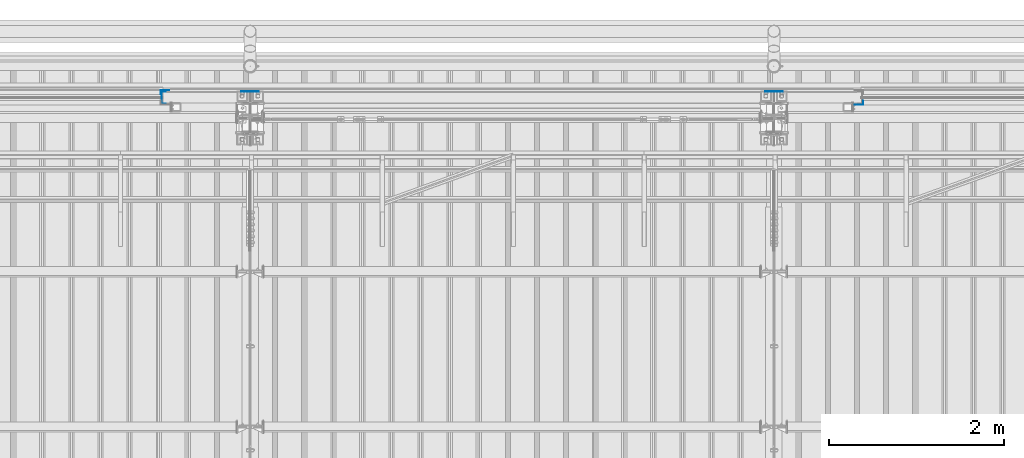
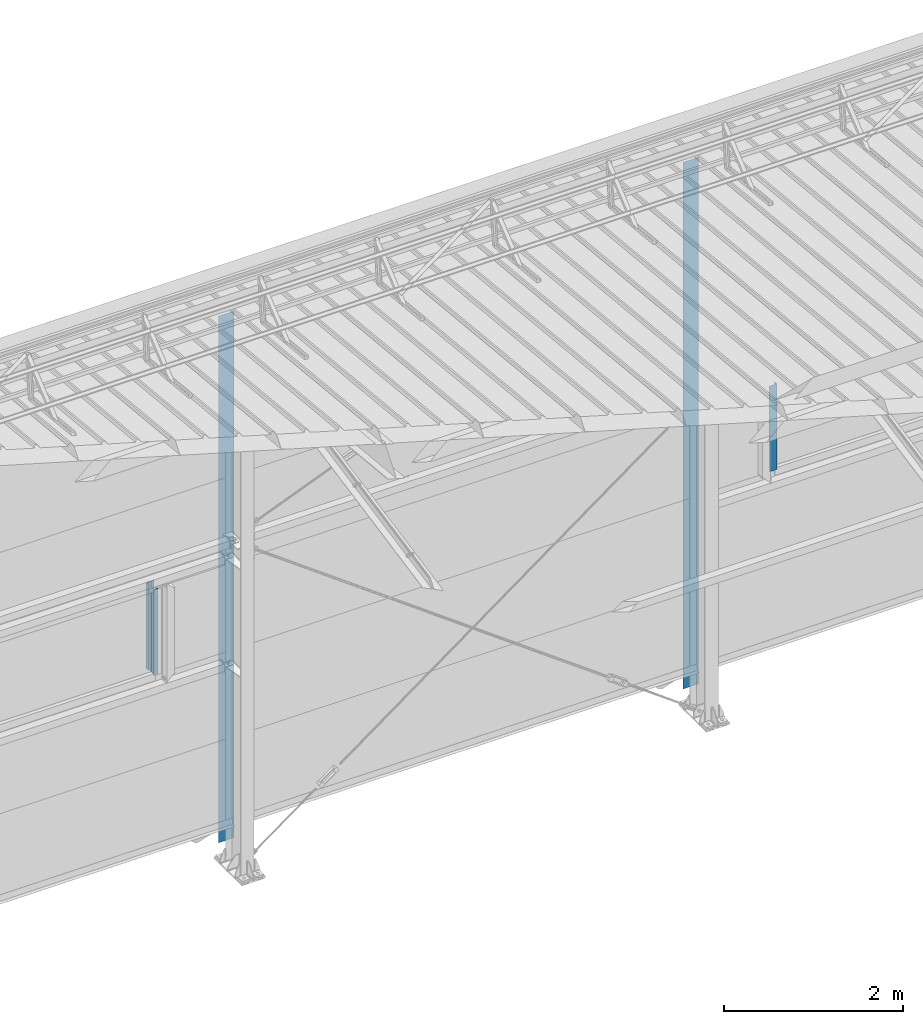
# One storey, part 10 of 709: 5 columns, 5 elements without a shape of their own.
"""IFC4 building model written with IfcOpenShell, lengths in millimetres."""

from ifc_helpers import new_model, si_unit, direction, frame, origin_with_axes, place, context, subcontext, project, spatial, line, indexed_curve, outline, extrude, material, element, aggregate, save


model = new_model("IFC4")

# Units and contexts
model_context = context("Model", 3, precision=0.2, world=origin_with_axes(), true_north=direction((0.0, 1.0)))
body_context = subcontext(model_context, "Body", "Model", "MODEL_VIEW")
ifc_project = project(units=[si_unit("LENGTHUNIT", "METRE", prefix="MILLI"), si_unit("AREAUNIT", "SQUARE_METRE"), si_unit("VOLUMEUNIT", "CUBIC_METRE"), si_unit("MASSUNIT", "GRAM", prefix="KILO"), si_unit("TIMEUNIT", "SECOND"), si_unit("PLANEANGLEUNIT", "RADIAN"), si_unit("SOLIDANGLEUNIT", "STERADIAN"), si_unit("THERMODYNAMICTEMPERATUREUNIT", "DEGREE_CELSIUS"), si_unit("LUMINOUSINTENSITYUNIT", "LUMEN")], contexts=[model_context])

# Site, building, storey
site_placement = place(None, origin_with_axes())
site = spatial("IfcSite", under=ifc_project, at=site_placement, CompositionType="ELEMENT")
building_placement = place(site_placement, origin_with_axes())
building = spatial("IfcBuilding", under=site, at=building_placement, Name="Undefined", CompositionType="ELEMENT")
storey_placement = place(building_placement, origin_with_axes())
storey = spatial("IfcBuildingStorey", under=building, at=storey_placement, Name="Undefined", CompositionType="ELEMENT", Elevation=0.0)

# Assembly, column
assembly_1_placement = place(storey_placement, frame((21010.0, 22060.0, 2700.0), z_axis=(0.0, -1.0, 0.0), x_axis=(0.0, 0.0, 1.0)))
assembly_1 = element("IfcElementAssembly", 1, at=assembly_1_placement, inside=storey)
ifc_material = material(Name="Steel_Undefined", Category="STEEL")
column_1_placement = place(assembly_1_placement, origin_with_axes())
column_1 = element("IfcColumn", 2, at=column_1_placement, material=ifc_material, context=body_context, shape_type="SolidModel", body=[
    extrude(outline(indexed_curve([(-70.0, -25.0), (-68.0, -25.0), (-68.0, 23.0), (68.0, 23.0), (68.0, -25.0), (70.0, -25.0), (70.0, 25.0), (-70.0, 25.0)], segments=[line(1, 2, 3, 4, 5, 6, 7, 8, 1)])), frame((0.0, 0.0, 0.0), z_axis=(-1.0, 0.0, 0.0), x_axis=(0.0, 0.0, 1.0)), (0.0, 0.0, -1.0), 1170.0),
])
aggregate(assembly_1, [column_1])

assembly_2_placement = place(storey_placement, frame((20975.0, 22121.0, 2700.0), z_axis=(0.0, 1.0, 0.0), x_axis=(0.0, 0.0, 1.0)))
assembly_2 = element("IfcElementAssembly", 3, at=assembly_2_placement, inside=storey)
column_2_placement = place(assembly_2_placement, origin_with_axes())
column_2 = element("IfcColumn", 4, at=column_2_placement, material=ifc_material, context=body_context, shape_type="SolidModel", body=[
    extrude(outline(indexed_curve([(-25.0, -1.0), (25.0, -1.0), (25.0, 99.0), (23.0, 99.0), (23.0, 1.0), (-25.0, 1.0)], segments=[line(1, 2, 3, 4, 5, 6, 1)])), frame((0.0, 0.0, 0.0), z_axis=(-1.0, 0.0, 0.0), x_axis=(0.0, 0.0, 1.0)), (0.0, 0.0, -1.0), 1170.0),
])
aggregate(assembly_2, [column_2])

assembly_3_placement = place(storey_placement, frame((29025.0, 22001.0, 2700.0), z_axis=(0.0, -1.0, 0.0), x_axis=(0.0, 0.0, 1.0)))
assembly_3 = element("IfcElementAssembly", 5, at=assembly_3_placement, inside=storey)
column_3_placement = place(assembly_3_placement, origin_with_axes())
column_3 = element("IfcColumn", 6, at=column_3_placement, material=ifc_material, context=body_context, shape_type="SolidModel", body=[
    extrude(outline(indexed_curve([(-25.0, -1.0), (25.0, -1.0), (25.0, 99.0), (23.0, 99.0), (23.0, 1.0), (-25.0, 1.0)], segments=[line(1, 2, 3, 4, 5, 6, 1)])), frame((0.0, 0.0, 0.0), z_axis=(-1.0, 0.0, 0.0), x_axis=(0.0, 0.0, 1.0)), (0.0, 0.0, -1.0), 1170.0),
])
aggregate(assembly_3, [column_3])

assembly_4_placement = place(storey_placement, frame((22000.0, 22130.0, 0.0), z_axis=(0.0, -1.0, 0.0), x_axis=(0.0, 0.0, 1.0)))
assembly_4 = element("IfcElementAssembly", 7, at=assembly_4_placement, inside=storey)
column_4_placement = place(assembly_4_placement, origin_with_axes())
column_4 = element("IfcColumn", 8, at=column_4_placement, material=ifc_material, context=body_context, shape_type="SolidModel", body=[
    extrude(outline(indexed_curve([(-0.375, -100.0), (1.245, -100.0), (1.245, -50.0), (0.495, -50.0), (0.495, -99.25), (0.375, -99.25), (0.375, 99.25), (0.495, 99.25), (0.495, 50.0), (1.245, 50.0), (1.245, 100.0), (-0.375, 100.0)], segments=[line(1, 2, 3, 4, 5, 6, 7, 8, 9, 10, 11, 12, 1)])), frame((0.0, 0.0, 0.0), z_axis=(-1.0, 0.0, 0.0), x_axis=(0.0, 0.0, 1.0)), (0.0, 0.0, -1.0), 7196.92297),
])
aggregate(assembly_4, [column_4])

assembly_5_placement = place(storey_placement, frame((28000.0, 22130.0, 0.0), z_axis=(0.0, -1.0, 0.0), x_axis=(0.0, 0.0, 1.0)))
assembly_5 = element("IfcElementAssembly", 9, at=assembly_5_placement, inside=storey)
column_5_placement = place(assembly_5_placement, origin_with_axes())
column_5 = element("IfcColumn", 10, at=column_5_placement, material=ifc_material, context=body_context, shape_type="SolidModel", body=[
    extrude(outline(indexed_curve([(-0.375, -100.0), (1.245, -100.0), (1.245, -50.0), (0.495, -50.0), (0.495, -99.25), (0.375, -99.25), (0.375, 99.25), (0.495, 99.25), (0.495, 50.0), (1.245, 50.0), (1.245, 100.0), (-0.375, 100.0)], segments=[line(1, 2, 3, 4, 5, 6, 7, 8, 9, 10, 11, 12, 1)])), frame((0.0, 0.0, 0.0), z_axis=(-1.0, 0.0, 0.0), x_axis=(0.0, 0.0, 1.0)), (0.0, 0.0, -1.0), 7196.92297),
])
aggregate(assembly_5, [column_5])

save(model, "model.ifc")
